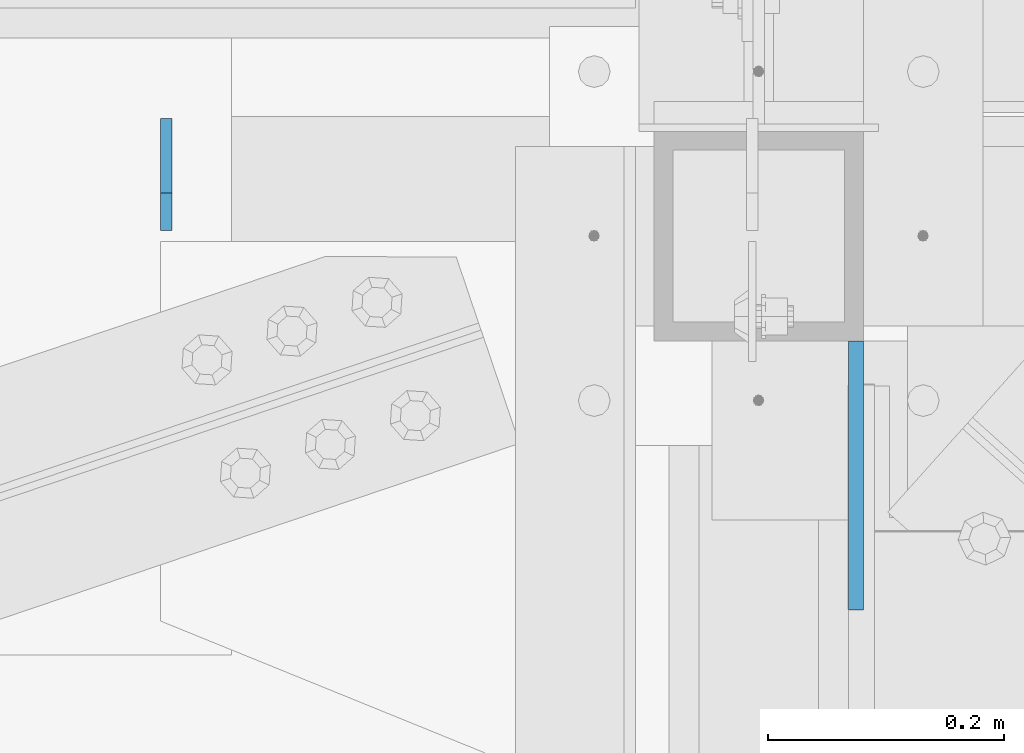
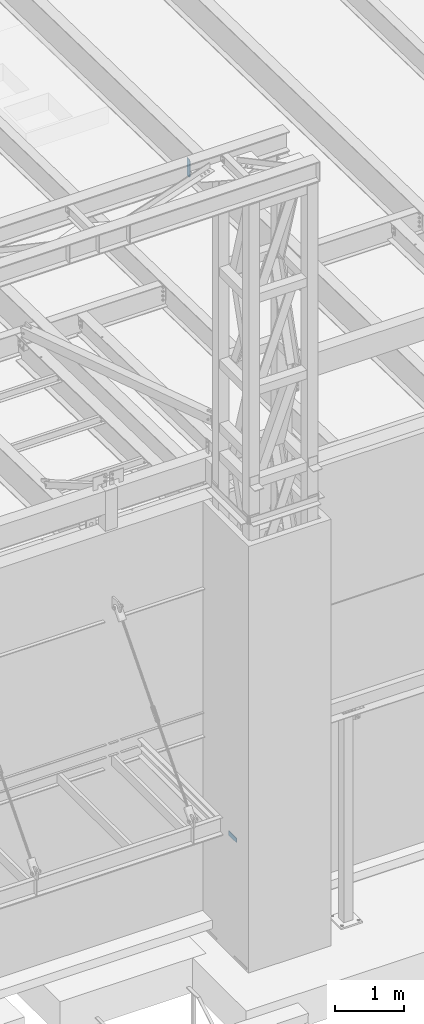
# One storey, part 1479 of 1763: 2 plates, 2 elements without a shape of their own.
"""IFC2X3 building model written with IfcOpenShell, lengths in millimetres."""

from ifc_helpers import new_model, si_unit, frame, origin_with_axes, place, context, subcontext, project, spatial, faceted_brep, material, type_object, element, aggregate, save


model = new_model("IFC2X3")

# Units and contexts
model_context = context("Model", 3, precision=1e-05, world=origin_with_axes())
body_context = subcontext(model_context, "Body", "Model", "MODEL_VIEW")
ifc_project = project(units=[si_unit("LENGTHUNIT", "METRE", prefix="MILLI"), si_unit("AREAUNIT", "SQUARE_METRE"), si_unit("VOLUMEUNIT", "CUBIC_METRE"), si_unit("MASSUNIT", "GRAM", prefix="KILO"), si_unit("TIMEUNIT", "SECOND"), si_unit("PLANEANGLEUNIT", "RADIAN"), si_unit("SOLIDANGLEUNIT", "STERADIAN"), si_unit("THERMODYNAMICTEMPERATUREUNIT", "DEGREE_CELSIUS"), si_unit("LUMINOUSINTENSITYUNIT", "LUMEN")], contexts=[model_context])

# Site, building, storey
site_placement = place(None, origin_with_axes())
site = spatial("IfcSite", under=ifc_project, at=site_placement, CompositionType="ELEMENT")
building_placement = place(site_placement, origin_with_axes())
building = spatial("IfcBuilding", under=site, at=building_placement, Name="Undefined", CompositionType="ELEMENT")
storey_placement = place(building_placement, origin_with_axes())
storey = spatial("IfcBuildingStorey", under=building, at=storey_placement, Name="Undefined", CompositionType="ELEMENT", Elevation=0.0)

# Assembly, plate
assembly_1_placement = place(storey_placement, origin_with_axes())
assembly_1 = element("IfcElementAssembly", 1, at=assembly_1_placement, inside=storey, Name="FRAME", AssemblyPlace="NOTDEFINED", PredefinedType="RIGID_FRAME")
ifc_material = material(Name="STEEL/A36")
plate_type_1 = type_object("IfcPlateType", PredefinedType="NOTDEFINED")
plate_1_placement = place(assembly_1_placement, frame((-47653.0022044142, -14897.1022094127, 6845.29999694824), z_axis=(0.0, 1.0, 0.0), x_axis=(0.0, 0.0, -1.0)))
plate_1 = element("IfcPlate", 2, at=plate_1_placement, type_object=plate_type_1, material=ifc_material, Name="PLATE", context=body_context, shape_type="Brep", body=[
    faceted_brep([(0.0, -6.34999999999491, 1.45519152283669e-11), (0.0, -6.35000000001855, 228.600006104178), (0.0, 6.34999999996944, 228.600006104134), (0.0, 6.34999999999491, -2.91038304567337e-11), (76.1999969482422, -6.35000000001855, 228.600006104178), (76.1999969482422, 6.34999999996944, 228.600006104134), (76.1999969482422, -6.34999999999491, 1.45519152283669e-11), (76.1999969482422, 6.34999999999491, -2.91038304567337e-11)], [[[0, 1, 2, 3]], [[1, 4, 5, 2]], [[4, 6, 7, 5]], [[6, 0, 3, 7]], [[5, 7, 3, 2]], [[6, 4, 1, 0]]]),
])
aggregate(assembly_1, [plate_1])

assembly_2_placement = place(storey_placement, origin_with_axes())
assembly_2 = element("IfcElementAssembly", 3, at=assembly_2_placement, inside=storey, Name="BEAM", AssemblyPlace="NOTDEFINED", PredefinedType="RIGID_FRAME")
plate_type_2 = type_object("IfcPlateType", PredefinedType="NOTDEFINED")
plate_2_placement = place(assembly_2_placement, frame((-48238.7899124043, -14574.8398057771, 18488.025), z_axis=(0.0, 0.0, 1.0), x_axis=(0.0, 1.0, 0.0)))
plate_2 = element("IfcPlate", 4, at=plate_2_placement, type_object=plate_type_2, material=ifc_material, Name="PLATE", context=body_context, shape_type="Brep", body=[
    faceted_brep([(0.0, -4.76250000000073, 31.75), (-3.63797880709171e-12, -4.76249999999709, 282.575012207031), (3.63797880709171e-12, 4.76249999999709, 282.575012207031), (0.0, 4.76250000000073, 31.75), (31.7499999999964, -4.7625000000844, 314.325012207031), (31.7500000000036, 4.76249999991705, 314.325012207031), (95.2499999999964, -4.76250000025902, 314.325012207031), (95.2500000000036, 4.76249999974243, 314.325012207031), (95.2499999999964, -4.76250000025902, 0.0), (95.2500000000036, 4.76249999974243, 0.0), (31.75, -4.76250000000073, 0.0), (31.75, 4.76250000000073, 0.0)], [[[0, 1, 2, 3]], [[1, 4, 5, 2]], [[4, 6, 7, 5]], [[6, 8, 9, 7]], [[8, 10, 11, 9]], [[10, 0, 3, 11]], [[5, 7, 9, 11, 3, 2]], [[10, 8, 6, 4, 1, 0]]]),
])
aggregate(assembly_2, [plate_2])

save(model, "model.ifc")
